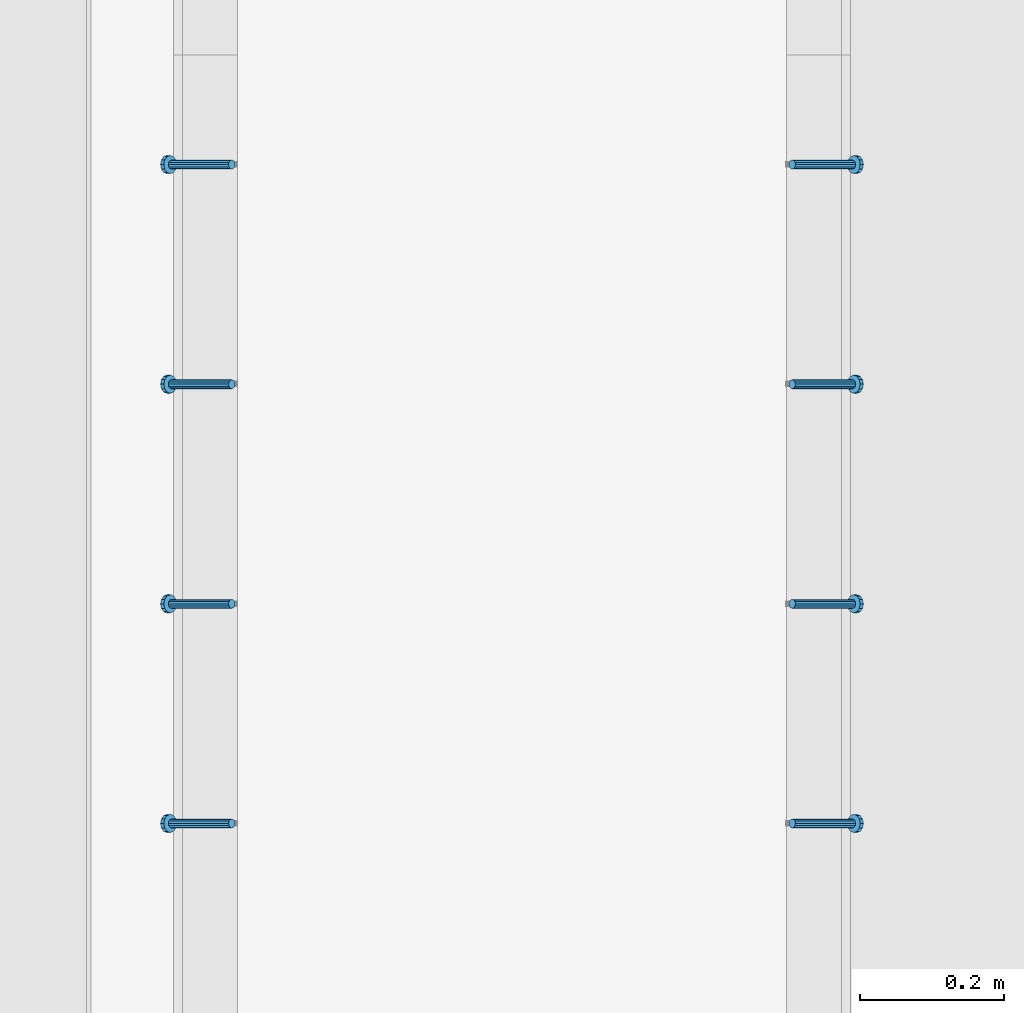
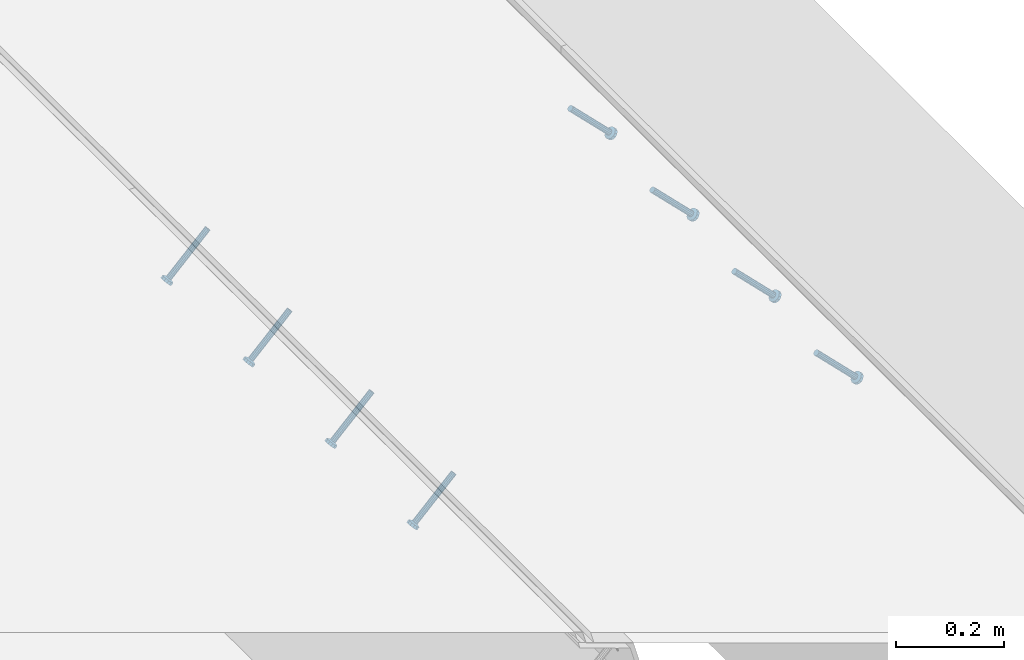
# One storey, part 2186 of 3843: 8 members, 2 elements without a shape of their own.
"""IFC2X3 building model written with IfcOpenShell, lengths in millimetres."""

from ifc_helpers import new_model, si_unit, frame, origin_with_axes, place, context, subcontext, project, spatial, faceted_brep, material, type_object, element, aggregate, save


model = new_model("IFC2X3")

# Units and contexts
model_context = context("Model", 3, precision=1e-05, world=origin_with_axes())
body_context = subcontext(model_context, "Body", "Model", "MODEL_VIEW")
ifc_project = project(units=[si_unit("LENGTHUNIT", "METRE", prefix="MILLI"), si_unit("AREAUNIT", "SQUARE_METRE"), si_unit("VOLUMEUNIT", "CUBIC_METRE"), si_unit("MASSUNIT", "GRAM", prefix="KILO"), si_unit("TIMEUNIT", "SECOND"), si_unit("PLANEANGLEUNIT", "RADIAN"), si_unit("SOLIDANGLEUNIT", "STERADIAN"), si_unit("THERMODYNAMICTEMPERATUREUNIT", "DEGREE_CELSIUS"), si_unit("LUMINOUSINTENSITYUNIT", "LUMEN")], contexts=[model_context])

# Site, building, storey
site_placement = place(None, origin_with_axes())
site = spatial("IfcSite", under=ifc_project, at=site_placement, CompositionType="ELEMENT")
building_placement = place(site_placement, origin_with_axes())
building = spatial("IfcBuilding", under=site, at=building_placement, Name="Undefined", CompositionType="ELEMENT")
storey_placement = place(building_placement, origin_with_axes())
storey = spatial("IfcBuildingStorey", under=building, at=storey_placement, Name="Undefined", CompositionType="ELEMENT", Elevation=0.0)

# Assembly, members
assembly_1_placement = place(storey_placement, origin_with_axes())
assembly_1 = element("IfcElementAssembly", 1, at=assembly_1_placement, inside=storey, Name="EMBED_ANGLE", AssemblyPlace="NOTDEFINED", PredefinedType="RIGID_FRAME")
ifc_material = material(Name="STEEL/A108")
member_type = type_object("IfcMemberType", PredefinedType="NOTDEFINED")
member_1_placement = place(assembly_1_placement, frame((44851.3834999999, 39779.575189209, 30456.1875), z_axis=(0.0, 1.0, 0.0), x_axis=(0.707106781186548, 0.0, -0.707106781186548)))
member_1 = element("IfcMember", 2, at=member_1_placement, type_object=member_type, material=ifc_material, Name="HEADED STUD ANCHOR", context=body_context, shape_type="Brep", body=[
    faceted_brep([(7.27595761418343e-12, -3.18000006675175, 5.5), (0.0, -5.49999999998363, 3.1800000667572), (118.110000000976, -5.49999999999091, 3.1800000667572), (118.110000000983, -3.18000006675175, 5.5), (0.0, -6.3499999046162, 0.0), (118.110000000968, -6.34999990461256, 0.0), (0.0, -5.49999999998363, -3.1800000667572), (118.110000000976, -5.49999999999091, -3.1800000667572), (7.27595761418343e-12, -3.18000006675175, -5.5), (118.110000000983, -3.18000006675175, -5.5), (7.27595761418343e-12, -1.81898940354586e-12, -6.34999990463257), (118.110000000968, -1.81898940354586e-12, -6.34999990463257), (0.0, 3.18000006675175, -5.5), (118.110000000968, 3.18000006674811, -5.5), (7.27595761418343e-12, 5.49999999998363, -3.1800000667572), (118.110000000983, 5.49999999998363, -3.1800000667572), (7.27595761418343e-12, 6.3499999046162, 0.0), (118.110000000976, 6.34999990461256, 0.0), (7.27595761418343e-12, 5.49999999998363, 3.1800000667572), (118.110000000983, 5.49999999998363, 3.1800000667572), (0.0, 3.18000006675175, 5.5), (118.110000000968, 3.18000006674811, 5.5), (7.27595761418343e-12, -1.81898940354586e-12, 6.34999990463257), (118.110000000968, -1.81898940354586e-12, 6.34999990463257), (120.650000000991, -10.9899997710909, 6.34999990463257), (120.650000000998, -6.34000015257152, 10.9899997711182), (120.650000000991, -12.6999998092379, 0.0), (120.650000000991, -10.9899997710909, -6.34999990463257), (120.650000000998, -6.34000015257152, -10.9899997711182), (120.650000000991, -1.81898940354586e-12, -12.6899995803833), (120.650000000991, 6.34000015257152, -10.9899997711182), (120.650000000998, 10.9899997710909, -6.34999990463257), (120.650000000991, 12.6999998092342, 0.0), (120.650000000998, 10.9899997710909, 6.34999990463257), (120.650000000991, 6.34000015257152, 10.9899997711182), (120.650000000991, -1.81898940354586e-12, 12.6899995803833), (127.000000001048, -10.9899997710945, 6.34999990463257), (127.000000001048, -6.34000015257152, 10.9899997711182), (127.000000001048, -12.6999998092342, 0.0), (127.000000001048, -10.9899997710945, -6.34999990463257), (127.000000001048, -6.34000015257152, -10.9899997711182), (127.000000001048, 1.81898940354586e-12, -12.6899995803833), (127.000000001048, 6.34000015256788, -10.9899997711182), (127.000000001048, 10.9899997710909, -6.34999990463257), (127.000000001048, 12.6999998092379, 0.0), (127.000000001048, 10.9899997710909, 6.34999990463257), (127.000000001048, 6.34000015256788, 10.9899997711182), (127.000000001048, 1.81898940354586e-12, 12.6899995803833)], [[[0, 1, 2, 3]], [[1, 4, 5, 2]], [[4, 6, 7, 5]], [[6, 8, 9, 7]], [[8, 10, 11, 9]], [[10, 12, 13, 11]], [[12, 14, 15, 13]], [[14, 16, 17, 15]], [[16, 18, 19, 17]], [[18, 20, 21, 19]], [[20, 22, 23, 21]], [[22, 0, 3, 23]], [[22, 20, 18, 16, 14, 12, 10, 8, 6, 4, 1, 0]], [[3, 2, 24, 25]], [[2, 5, 26, 24]], [[5, 7, 27, 26]], [[7, 9, 28, 27]], [[9, 11, 29, 28]], [[11, 13, 30, 29]], [[13, 15, 31, 30]], [[15, 17, 32, 31]], [[17, 19, 33, 32]], [[19, 21, 34, 33]], [[21, 23, 35, 34]], [[23, 3, 25, 35]], [[25, 24, 36, 37]], [[24, 26, 38, 36]], [[26, 27, 39, 38]], [[27, 28, 40, 39]], [[28, 29, 41, 40]], [[29, 30, 42, 41]], [[30, 31, 43, 42]], [[31, 32, 44, 43]], [[32, 33, 45, 44]], [[33, 34, 46, 45]], [[34, 35, 47, 46]], [[35, 25, 37, 47]], [[38, 39, 40, 41, 42, 43, 44, 45, 46, 47, 37, 36]]]),
])
member_2_placement = place(assembly_1_placement, frame((44851.3834999999, 40084.375189209, 30456.1875), z_axis=(0.0, 1.0, 0.0), x_axis=(0.707106781186548, 0.0, -0.707106781186548)))
member_2 = element("IfcMember", 3, at=member_2_placement, type_object=member_type, material=ifc_material, Name="HEADED STUD ANCHOR", context=body_context, shape_type="Brep", body=[
    faceted_brep([(7.27595761418343e-12, -3.18000006675175, 5.5), (0.0, -5.49999999998363, 3.1800000667572), (118.110000000976, -5.49999999999091, 3.1800000667572), (118.110000000983, -3.18000006675175, 5.5), (0.0, -6.3499999046162, 0.0), (118.110000000968, -6.34999990461256, 0.0), (0.0, -5.49999999998363, -3.1800000667572), (118.110000000976, -5.49999999999091, -3.1800000667572), (7.27595761418343e-12, -3.18000006675175, -5.5), (118.110000000983, -3.18000006675175, -5.5), (7.27595761418343e-12, -1.81898940354586e-12, -6.34999990463257), (118.110000000968, -1.81898940354586e-12, -6.34999990463257), (0.0, 3.18000006675175, -5.5), (118.110000000968, 3.18000006674811, -5.5), (7.27595761418343e-12, 5.49999999998363, -3.1800000667572), (118.110000000983, 5.49999999998363, -3.1800000667572), (7.27595761418343e-12, 6.3499999046162, 0.0), (118.110000000976, 6.34999990461256, 0.0), (7.27595761418343e-12, 5.49999999998363, 3.1800000667572), (118.110000000983, 5.49999999998363, 3.1800000667572), (0.0, 3.18000006675175, 5.5), (118.110000000968, 3.18000006674811, 5.5), (7.27595761418343e-12, -1.81898940354586e-12, 6.34999990463257), (118.110000000968, -1.81898940354586e-12, 6.34999990463257), (120.650000000991, -10.9899997710909, 6.34999990463257), (120.650000000998, -6.34000015257152, 10.9899997711182), (120.650000000991, -12.6999998092379, 0.0), (120.650000000991, -10.9899997710909, -6.34999990463257), (120.650000000998, -6.34000015257152, -10.9899997711182), (120.650000000991, -1.81898940354586e-12, -12.6899995803833), (120.650000000991, 6.34000015257152, -10.9899997711182), (120.650000000998, 10.9899997710909, -6.34999990463257), (120.650000000991, 12.6999998092342, 0.0), (120.650000000998, 10.9899997710909, 6.34999990463257), (120.650000000991, 6.34000015257152, 10.9899997711182), (120.650000000991, -1.81898940354586e-12, 12.6899995803833), (127.000000001048, -10.9899997710945, 6.34999990463257), (127.000000001048, -6.34000015257152, 10.9899997711182), (127.000000001048, -12.6999998092342, 0.0), (127.000000001048, -10.9899997710945, -6.34999990463257), (127.000000001048, -6.34000015257152, -10.9899997711182), (127.000000001048, 1.81898940354586e-12, -12.6899995803833), (127.000000001048, 6.34000015256788, -10.9899997711182), (127.000000001048, 10.9899997710909, -6.34999990463257), (127.000000001048, 12.6999998092379, 0.0), (127.000000001048, 10.9899997710909, 6.34999990463257), (127.000000001048, 6.34000015256788, 10.9899997711182), (127.000000001048, 1.81898940354586e-12, 12.6899995803833)], [[[0, 1, 2, 3]], [[1, 4, 5, 2]], [[4, 6, 7, 5]], [[6, 8, 9, 7]], [[8, 10, 11, 9]], [[10, 12, 13, 11]], [[12, 14, 15, 13]], [[14, 16, 17, 15]], [[16, 18, 19, 17]], [[18, 20, 21, 19]], [[20, 22, 23, 21]], [[22, 0, 3, 23]], [[22, 20, 18, 16, 14, 12, 10, 8, 6, 4, 1, 0]], [[3, 2, 24, 25]], [[2, 5, 26, 24]], [[5, 7, 27, 26]], [[7, 9, 28, 27]], [[9, 11, 29, 28]], [[11, 13, 30, 29]], [[13, 15, 31, 30]], [[15, 17, 32, 31]], [[17, 19, 33, 32]], [[19, 21, 34, 33]], [[21, 23, 35, 34]], [[23, 3, 25, 35]], [[25, 24, 36, 37]], [[24, 26, 38, 36]], [[26, 27, 39, 38]], [[27, 28, 40, 39]], [[28, 29, 41, 40]], [[29, 30, 42, 41]], [[30, 31, 43, 42]], [[31, 32, 44, 43]], [[32, 33, 45, 44]], [[33, 34, 46, 45]], [[34, 35, 47, 46]], [[35, 25, 37, 47]], [[38, 39, 40, 41, 42, 43, 44, 45, 46, 47, 37, 36]]]),
])
member_3_placement = place(assembly_1_placement, frame((44851.3834999999, 40389.175189209, 30456.1875), z_axis=(0.0, 1.0, 0.0), x_axis=(0.707106781186548, 0.0, -0.707106781186548)))
member_3 = element("IfcMember", 4, at=member_3_placement, type_object=member_type, material=ifc_material, Name="HEADED STUD ANCHOR", context=body_context, shape_type="Brep", body=[
    faceted_brep([(7.27595761418343e-12, -3.18000006675175, 5.5), (0.0, -5.49999999998363, 3.1800000667572), (118.110000000976, -5.49999999999091, 3.1800000667572), (118.110000000983, -3.18000006675175, 5.5), (0.0, -6.3499999046162, 0.0), (118.110000000968, -6.34999990461256, 0.0), (0.0, -5.49999999998363, -3.1800000667572), (118.110000000976, -5.49999999999091, -3.1800000667572), (7.27595761418343e-12, -3.18000006675175, -5.5), (118.110000000983, -3.18000006675175, -5.5), (7.27595761418343e-12, -1.81898940354586e-12, -6.34999990463257), (118.110000000968, -1.81898940354586e-12, -6.34999990463257), (0.0, 3.18000006675175, -5.5), (118.110000000968, 3.18000006674811, -5.5), (7.27595761418343e-12, 5.49999999998363, -3.1800000667572), (118.110000000983, 5.49999999998363, -3.1800000667572), (7.27595761418343e-12, 6.3499999046162, 0.0), (118.110000000976, 6.34999990461256, 0.0), (7.27595761418343e-12, 5.49999999998363, 3.1800000667572), (118.110000000983, 5.49999999998363, 3.1800000667572), (0.0, 3.18000006675175, 5.5), (118.110000000968, 3.18000006674811, 5.5), (7.27595761418343e-12, -1.81898940354586e-12, 6.34999990463257), (118.110000000968, -1.81898940354586e-12, 6.34999990463257), (120.650000000991, -10.9899997710909, 6.34999990463257), (120.650000000998, -6.34000015257152, 10.9899997711182), (120.650000000991, -12.6999998092379, 0.0), (120.650000000991, -10.9899997710909, -6.34999990463257), (120.650000000998, -6.34000015257152, -10.9899997711182), (120.650000000991, -1.81898940354586e-12, -12.6899995803833), (120.650000000991, 6.34000015257152, -10.9899997711182), (120.650000000998, 10.9899997710909, -6.34999990463257), (120.650000000991, 12.6999998092342, 0.0), (120.650000000998, 10.9899997710909, 6.34999990463257), (120.650000000991, 6.34000015257152, 10.9899997711182), (120.650000000991, -1.81898940354586e-12, 12.6899995803833), (127.000000001048, -10.9899997710945, 6.34999990463257), (127.000000001048, -6.34000015257152, 10.9899997711182), (127.000000001048, -12.6999998092342, 0.0), (127.000000001048, -10.9899997710945, -6.34999990463257), (127.000000001048, -6.34000015257152, -10.9899997711182), (127.000000001048, 1.81898940354586e-12, -12.6899995803833), (127.000000001048, 6.34000015256788, -10.9899997711182), (127.000000001048, 10.9899997710909, -6.34999990463257), (127.000000001048, 12.6999998092379, 0.0), (127.000000001048, 10.9899997710909, 6.34999990463257), (127.000000001048, 6.34000015256788, 10.9899997711182), (127.000000001048, 1.81898940354586e-12, 12.6899995803833)], [[[0, 1, 2, 3]], [[1, 4, 5, 2]], [[4, 6, 7, 5]], [[6, 8, 9, 7]], [[8, 10, 11, 9]], [[10, 12, 13, 11]], [[12, 14, 15, 13]], [[14, 16, 17, 15]], [[16, 18, 19, 17]], [[18, 20, 21, 19]], [[20, 22, 23, 21]], [[22, 0, 3, 23]], [[22, 20, 18, 16, 14, 12, 10, 8, 6, 4, 1, 0]], [[3, 2, 24, 25]], [[2, 5, 26, 24]], [[5, 7, 27, 26]], [[7, 9, 28, 27]], [[9, 11, 29, 28]], [[11, 13, 30, 29]], [[13, 15, 31, 30]], [[15, 17, 32, 31]], [[17, 19, 33, 32]], [[19, 21, 34, 33]], [[21, 23, 35, 34]], [[23, 3, 25, 35]], [[25, 24, 36, 37]], [[24, 26, 38, 36]], [[26, 27, 39, 38]], [[27, 28, 40, 39]], [[28, 29, 41, 40]], [[29, 30, 42, 41]], [[30, 31, 43, 42]], [[31, 32, 44, 43]], [[32, 33, 45, 44]], [[33, 34, 46, 45]], [[34, 35, 47, 46]], [[35, 25, 37, 47]], [[38, 39, 40, 41, 42, 43, 44, 45, 46, 47, 37, 36]]]),
])
member_4_placement = place(assembly_1_placement, frame((44851.3834999999, 40693.975189209, 30456.1875), z_axis=(0.0, 1.0, 0.0), x_axis=(0.707106781186548, 0.0, -0.707106781186548)))
member_4 = element("IfcMember", 5, at=member_4_placement, type_object=member_type, material=ifc_material, Name="HEADED STUD ANCHOR", context=body_context, shape_type="Brep", body=[
    faceted_brep([(7.27595761418343e-12, -3.18000006675175, 5.5), (0.0, -5.49999999998363, 3.1800000667572), (118.110000000976, -5.49999999999091, 3.1800000667572), (118.110000000983, -3.18000006675175, 5.5), (0.0, -6.3499999046162, 0.0), (118.110000000968, -6.34999990461256, 0.0), (0.0, -5.49999999998363, -3.1800000667572), (118.110000000976, -5.49999999999091, -3.1800000667572), (7.27595761418343e-12, -3.18000006675175, -5.5), (118.110000000983, -3.18000006675175, -5.5), (7.27595761418343e-12, -1.81898940354586e-12, -6.34999990463257), (118.110000000968, -1.81898940354586e-12, -6.34999990463257), (0.0, 3.18000006675175, -5.5), (118.110000000968, 3.18000006674811, -5.5), (7.27595761418343e-12, 5.49999999998363, -3.1800000667572), (118.110000000983, 5.49999999998363, -3.1800000667572), (7.27595761418343e-12, 6.3499999046162, 0.0), (118.110000000976, 6.34999990461256, 0.0), (7.27595761418343e-12, 5.49999999998363, 3.1800000667572), (118.110000000983, 5.49999999998363, 3.1800000667572), (0.0, 3.18000006675175, 5.5), (118.110000000968, 3.18000006674811, 5.5), (7.27595761418343e-12, -1.81898940354586e-12, 6.34999990463257), (118.110000000968, -1.81898940354586e-12, 6.34999990463257), (120.650000000991, -10.9899997710909, 6.34999990463257), (120.650000000998, -6.34000015257152, 10.9899997711182), (120.650000000991, -12.6999998092379, 0.0), (120.650000000991, -10.9899997710909, -6.34999990463257), (120.650000000998, -6.34000015257152, -10.9899997711182), (120.650000000991, -1.81898940354586e-12, -12.6899995803833), (120.650000000991, 6.34000015257152, -10.9899997711182), (120.650000000998, 10.9899997710909, -6.34999990463257), (120.650000000991, 12.6999998092342, 0.0), (120.650000000998, 10.9899997710909, 6.34999990463257), (120.650000000991, 6.34000015257152, 10.9899997711182), (120.650000000991, -1.81898940354586e-12, 12.6899995803833), (127.000000001048, -10.9899997710945, 6.34999990463257), (127.000000001048, -6.34000015257152, 10.9899997711182), (127.000000001048, -12.6999998092342, 0.0), (127.000000001048, -10.9899997710945, -6.34999990463257), (127.000000001048, -6.34000015257152, -10.9899997711182), (127.000000001048, 1.81898940354586e-12, -12.6899995803833), (127.000000001048, 6.34000015256788, -10.9899997711182), (127.000000001048, 10.9899997710909, -6.34999990463257), (127.000000001048, 12.6999998092379, 0.0), (127.000000001048, 10.9899997710909, 6.34999990463257), (127.000000001048, 6.34000015256788, 10.9899997711182), (127.000000001048, 1.81898940354586e-12, 12.6899995803833)], [[[0, 1, 2, 3]], [[1, 4, 5, 2]], [[4, 6, 7, 5]], [[6, 8, 9, 7]], [[8, 10, 11, 9]], [[10, 12, 13, 11]], [[12, 14, 15, 13]], [[14, 16, 17, 15]], [[16, 18, 19, 17]], [[18, 20, 21, 19]], [[20, 22, 23, 21]], [[22, 0, 3, 23]], [[22, 20, 18, 16, 14, 12, 10, 8, 6, 4, 1, 0]], [[3, 2, 24, 25]], [[2, 5, 26, 24]], [[5, 7, 27, 26]], [[7, 9, 28, 27]], [[9, 11, 29, 28]], [[11, 13, 30, 29]], [[13, 15, 31, 30]], [[15, 17, 32, 31]], [[17, 19, 33, 32]], [[19, 21, 34, 33]], [[21, 23, 35, 34]], [[23, 3, 25, 35]], [[25, 24, 36, 37]], [[24, 26, 38, 36]], [[26, 27, 39, 38]], [[27, 28, 40, 39]], [[28, 29, 41, 40]], [[29, 30, 42, 41]], [[30, 31, 43, 42]], [[31, 32, 44, 43]], [[32, 33, 45, 44]], [[33, 34, 46, 45]], [[34, 35, 47, 46]], [[35, 25, 37, 47]], [[38, 39, 40, 41, 42, 43, 44, 45, 46, 47, 37, 36]]]),
])
aggregate(assembly_1, [member_1, member_2, member_3, member_4])

assembly_2_placement = place(storey_placement, origin_with_axes())
assembly_2 = element("IfcElementAssembly", 6, at=assembly_2_placement, inside=storey, Name="EMBED_ANGLE", AssemblyPlace="NOTDEFINED", PredefinedType="RIGID_FRAME")
member_5_placement = place(assembly_2_placement, frame((44073.5085000003, 39779.575189209, 30456.1874999998), z_axis=(0.0, -1.0, 0.0), x_axis=(-0.707106781186548, 0.0, -0.707106781186548)))
member_5 = element("IfcMember", 7, at=member_5_placement, type_object=member_type, material=ifc_material, Name="HEADED STUD ANCHOR", context=body_context, shape_type="Brep", body=[
    faceted_brep([(7.27595761418343e-12, -3.18000006675175, 5.5), (0.0, -5.49999999998363, 3.1800000667572), (118.110000000976, -5.49999999999091, 3.1800000667572), (118.110000000983, -3.18000006675175, 5.5), (0.0, -6.3499999046162, 0.0), (118.110000000968, -6.34999990461256, 0.0), (0.0, -5.49999999998363, -3.1800000667572), (118.110000000976, -5.49999999999091, -3.1800000667572), (7.27595761418343e-12, -3.18000006675175, -5.5), (118.110000000983, -3.18000006675175, -5.5), (7.27595761418343e-12, -1.81898940354586e-12, -6.34999990463257), (118.110000000968, -1.81898940354586e-12, -6.34999990463257), (0.0, 3.18000006675175, -5.5), (118.110000000968, 3.18000006674811, -5.5), (7.27595761418343e-12, 5.49999999998363, -3.1800000667572), (118.110000000983, 5.49999999998363, -3.1800000667572), (7.27595761418343e-12, 6.3499999046162, 0.0), (118.110000000976, 6.34999990461256, 0.0), (7.27595761418343e-12, 5.49999999998363, 3.1800000667572), (118.110000000983, 5.49999999998363, 3.1800000667572), (0.0, 3.18000006675175, 5.5), (118.110000000968, 3.18000006674811, 5.5), (7.27595761418343e-12, -1.81898940354586e-12, 6.34999990463257), (118.110000000968, -1.81898940354586e-12, 6.34999990463257), (120.650000000991, -10.9899997710909, 6.34999990463257), (120.650000000998, -6.34000015257152, 10.9899997711182), (120.650000000991, -12.6999998092379, 0.0), (120.650000000991, -10.9899997710909, -6.34999990463257), (120.650000000998, -6.34000015257152, -10.9899997711182), (120.650000000991, -1.81898940354586e-12, -12.6899995803833), (120.650000000991, 6.34000015257152, -10.9899997711182), (120.650000000998, 10.9899997710909, -6.34999990463257), (120.650000000991, 12.6999998092342, 0.0), (120.650000000998, 10.9899997710909, 6.34999990463257), (120.650000000991, 6.34000015257152, 10.9899997711182), (120.650000000991, -1.81898940354586e-12, 12.6899995803833), (127.000000001048, -10.9899997710945, 6.34999990463257), (127.000000001048, -6.34000015257152, 10.9899997711182), (127.000000001048, -12.6999998092342, 0.0), (127.000000001048, -10.9899997710945, -6.34999990463257), (127.000000001048, -6.34000015257152, -10.9899997711182), (127.000000001048, 1.81898940354586e-12, -12.6899995803833), (127.000000001048, 6.34000015256788, -10.9899997711182), (127.000000001048, 10.9899997710909, -6.34999990463257), (127.000000001048, 12.6999998092379, 0.0), (127.000000001048, 10.9899997710909, 6.34999990463257), (127.000000001048, 6.34000015256788, 10.9899997711182), (127.000000001048, 1.81898940354586e-12, 12.6899995803833)], [[[0, 1, 2, 3]], [[1, 4, 5, 2]], [[4, 6, 7, 5]], [[6, 8, 9, 7]], [[8, 10, 11, 9]], [[10, 12, 13, 11]], [[12, 14, 15, 13]], [[14, 16, 17, 15]], [[16, 18, 19, 17]], [[18, 20, 21, 19]], [[20, 22, 23, 21]], [[22, 0, 3, 23]], [[22, 20, 18, 16, 14, 12, 10, 8, 6, 4, 1, 0]], [[3, 2, 24, 25]], [[2, 5, 26, 24]], [[5, 7, 27, 26]], [[7, 9, 28, 27]], [[9, 11, 29, 28]], [[11, 13, 30, 29]], [[13, 15, 31, 30]], [[15, 17, 32, 31]], [[17, 19, 33, 32]], [[19, 21, 34, 33]], [[21, 23, 35, 34]], [[23, 3, 25, 35]], [[25, 24, 36, 37]], [[24, 26, 38, 36]], [[26, 27, 39, 38]], [[27, 28, 40, 39]], [[28, 29, 41, 40]], [[29, 30, 42, 41]], [[30, 31, 43, 42]], [[31, 32, 44, 43]], [[32, 33, 45, 44]], [[33, 34, 46, 45]], [[34, 35, 47, 46]], [[35, 25, 37, 47]], [[38, 39, 40, 41, 42, 43, 44, 45, 46, 47, 37, 36]]]),
])
member_6_placement = place(assembly_2_placement, frame((44073.5085000003, 40084.375189209, 30456.1874999998), z_axis=(0.0, -1.0, 0.0), x_axis=(-0.707106781186548, 0.0, -0.707106781186548)))
member_6 = element("IfcMember", 8, at=member_6_placement, type_object=member_type, material=ifc_material, Name="HEADED STUD ANCHOR", context=body_context, shape_type="Brep", body=[
    faceted_brep([(7.27595761418343e-12, -3.18000006675175, 5.5), (0.0, -5.49999999998363, 3.1800000667572), (118.110000000976, -5.49999999999091, 3.1800000667572), (118.110000000983, -3.18000006675175, 5.5), (0.0, -6.3499999046162, 0.0), (118.110000000968, -6.34999990461256, 0.0), (0.0, -5.49999999998363, -3.1800000667572), (118.110000000976, -5.49999999999091, -3.1800000667572), (7.27595761418343e-12, -3.18000006675175, -5.5), (118.110000000983, -3.18000006675175, -5.5), (7.27595761418343e-12, -1.81898940354586e-12, -6.34999990463257), (118.110000000968, -1.81898940354586e-12, -6.34999990463257), (0.0, 3.18000006675175, -5.5), (118.110000000968, 3.18000006674811, -5.5), (7.27595761418343e-12, 5.49999999998363, -3.1800000667572), (118.110000000983, 5.49999999998363, -3.1800000667572), (7.27595761418343e-12, 6.3499999046162, 0.0), (118.110000000976, 6.34999990461256, 0.0), (7.27595761418343e-12, 5.49999999998363, 3.1800000667572), (118.110000000983, 5.49999999998363, 3.1800000667572), (0.0, 3.18000006675175, 5.5), (118.110000000968, 3.18000006674811, 5.5), (7.27595761418343e-12, -1.81898940354586e-12, 6.34999990463257), (118.110000000968, -1.81898940354586e-12, 6.34999990463257), (120.650000000991, -10.9899997710909, 6.34999990463257), (120.650000000998, -6.34000015257152, 10.9899997711182), (120.650000000991, -12.6999998092379, 0.0), (120.650000000991, -10.9899997710909, -6.34999990463257), (120.650000000998, -6.34000015257152, -10.9899997711182), (120.650000000991, -1.81898940354586e-12, -12.6899995803833), (120.650000000991, 6.34000015257152, -10.9899997711182), (120.650000000998, 10.9899997710909, -6.34999990463257), (120.650000000991, 12.6999998092342, 0.0), (120.650000000998, 10.9899997710909, 6.34999990463257), (120.650000000991, 6.34000015257152, 10.9899997711182), (120.650000000991, -1.81898940354586e-12, 12.6899995803833), (127.000000001048, -10.9899997710945, 6.34999990463257), (127.000000001048, -6.34000015257152, 10.9899997711182), (127.000000001048, -12.6999998092342, 0.0), (127.000000001048, -10.9899997710945, -6.34999990463257), (127.000000001048, -6.34000015257152, -10.9899997711182), (127.000000001048, 1.81898940354586e-12, -12.6899995803833), (127.000000001048, 6.34000015256788, -10.9899997711182), (127.000000001048, 10.9899997710909, -6.34999990463257), (127.000000001048, 12.6999998092379, 0.0), (127.000000001048, 10.9899997710909, 6.34999990463257), (127.000000001048, 6.34000015256788, 10.9899997711182), (127.000000001048, 1.81898940354586e-12, 12.6899995803833)], [[[0, 1, 2, 3]], [[1, 4, 5, 2]], [[4, 6, 7, 5]], [[6, 8, 9, 7]], [[8, 10, 11, 9]], [[10, 12, 13, 11]], [[12, 14, 15, 13]], [[14, 16, 17, 15]], [[16, 18, 19, 17]], [[18, 20, 21, 19]], [[20, 22, 23, 21]], [[22, 0, 3, 23]], [[22, 20, 18, 16, 14, 12, 10, 8, 6, 4, 1, 0]], [[3, 2, 24, 25]], [[2, 5, 26, 24]], [[5, 7, 27, 26]], [[7, 9, 28, 27]], [[9, 11, 29, 28]], [[11, 13, 30, 29]], [[13, 15, 31, 30]], [[15, 17, 32, 31]], [[17, 19, 33, 32]], [[19, 21, 34, 33]], [[21, 23, 35, 34]], [[23, 3, 25, 35]], [[25, 24, 36, 37]], [[24, 26, 38, 36]], [[26, 27, 39, 38]], [[27, 28, 40, 39]], [[28, 29, 41, 40]], [[29, 30, 42, 41]], [[30, 31, 43, 42]], [[31, 32, 44, 43]], [[32, 33, 45, 44]], [[33, 34, 46, 45]], [[34, 35, 47, 46]], [[35, 25, 37, 47]], [[38, 39, 40, 41, 42, 43, 44, 45, 46, 47, 37, 36]]]),
])
member_7_placement = place(assembly_2_placement, frame((44073.5085000003, 40389.175189209, 30456.1874999998), z_axis=(0.0, -1.0, 0.0), x_axis=(-0.707106781186548, 0.0, -0.707106781186548)))
member_7 = element("IfcMember", 9, at=member_7_placement, type_object=member_type, material=ifc_material, Name="HEADED STUD ANCHOR", context=body_context, shape_type="Brep", body=[
    faceted_brep([(7.27595761418343e-12, -3.18000006675175, 5.5), (0.0, -5.49999999998363, 3.1800000667572), (118.110000000976, -5.49999999999091, 3.1800000667572), (118.110000000983, -3.18000006675175, 5.5), (0.0, -6.3499999046162, 0.0), (118.110000000968, -6.34999990461256, 0.0), (0.0, -5.49999999998363, -3.1800000667572), (118.110000000976, -5.49999999999091, -3.1800000667572), (7.27595761418343e-12, -3.18000006675175, -5.5), (118.110000000983, -3.18000006675175, -5.5), (7.27595761418343e-12, -1.81898940354586e-12, -6.34999990463257), (118.110000000968, -1.81898940354586e-12, -6.34999990463257), (0.0, 3.18000006675175, -5.5), (118.110000000968, 3.18000006674811, -5.5), (7.27595761418343e-12, 5.49999999998363, -3.1800000667572), (118.110000000983, 5.49999999998363, -3.1800000667572), (7.27595761418343e-12, 6.3499999046162, 0.0), (118.110000000976, 6.34999990461256, 0.0), (7.27595761418343e-12, 5.49999999998363, 3.1800000667572), (118.110000000983, 5.49999999998363, 3.1800000667572), (0.0, 3.18000006675175, 5.5), (118.110000000968, 3.18000006674811, 5.5), (7.27595761418343e-12, -1.81898940354586e-12, 6.34999990463257), (118.110000000968, -1.81898940354586e-12, 6.34999990463257), (120.650000000991, -10.9899997710909, 6.34999990463257), (120.650000000998, -6.34000015257152, 10.9899997711182), (120.650000000991, -12.6999998092379, 0.0), (120.650000000991, -10.9899997710909, -6.34999990463257), (120.650000000998, -6.34000015257152, -10.9899997711182), (120.650000000991, -1.81898940354586e-12, -12.6899995803833), (120.650000000991, 6.34000015257152, -10.9899997711182), (120.650000000998, 10.9899997710909, -6.34999990463257), (120.650000000991, 12.6999998092342, 0.0), (120.650000000998, 10.9899997710909, 6.34999990463257), (120.650000000991, 6.34000015257152, 10.9899997711182), (120.650000000991, -1.81898940354586e-12, 12.6899995803833), (127.000000001048, -10.9899997710945, 6.34999990463257), (127.000000001048, -6.34000015257152, 10.9899997711182), (127.000000001048, -12.6999998092342, 0.0), (127.000000001048, -10.9899997710945, -6.34999990463257), (127.000000001048, -6.34000015257152, -10.9899997711182), (127.000000001048, 1.81898940354586e-12, -12.6899995803833), (127.000000001048, 6.34000015256788, -10.9899997711182), (127.000000001048, 10.9899997710909, -6.34999990463257), (127.000000001048, 12.6999998092379, 0.0), (127.000000001048, 10.9899997710909, 6.34999990463257), (127.000000001048, 6.34000015256788, 10.9899997711182), (127.000000001048, 1.81898940354586e-12, 12.6899995803833)], [[[0, 1, 2, 3]], [[1, 4, 5, 2]], [[4, 6, 7, 5]], [[6, 8, 9, 7]], [[8, 10, 11, 9]], [[10, 12, 13, 11]], [[12, 14, 15, 13]], [[14, 16, 17, 15]], [[16, 18, 19, 17]], [[18, 20, 21, 19]], [[20, 22, 23, 21]], [[22, 0, 3, 23]], [[22, 20, 18, 16, 14, 12, 10, 8, 6, 4, 1, 0]], [[3, 2, 24, 25]], [[2, 5, 26, 24]], [[5, 7, 27, 26]], [[7, 9, 28, 27]], [[9, 11, 29, 28]], [[11, 13, 30, 29]], [[13, 15, 31, 30]], [[15, 17, 32, 31]], [[17, 19, 33, 32]], [[19, 21, 34, 33]], [[21, 23, 35, 34]], [[23, 3, 25, 35]], [[25, 24, 36, 37]], [[24, 26, 38, 36]], [[26, 27, 39, 38]], [[27, 28, 40, 39]], [[28, 29, 41, 40]], [[29, 30, 42, 41]], [[30, 31, 43, 42]], [[31, 32, 44, 43]], [[32, 33, 45, 44]], [[33, 34, 46, 45]], [[34, 35, 47, 46]], [[35, 25, 37, 47]], [[38, 39, 40, 41, 42, 43, 44, 45, 46, 47, 37, 36]]]),
])
member_8_placement = place(assembly_2_placement, frame((44073.5085000003, 40693.975189209, 30456.1874999998), z_axis=(0.0, -1.0, 0.0), x_axis=(-0.707106781186548, 0.0, -0.707106781186548)))
member_8 = element("IfcMember", 10, at=member_8_placement, type_object=member_type, material=ifc_material, Name="HEADED STUD ANCHOR", context=body_context, shape_type="Brep", body=[
    faceted_brep([(7.27595761418343e-12, -3.18000006675175, 5.5), (0.0, -5.49999999998363, 3.1800000667572), (118.110000000976, -5.49999999999091, 3.1800000667572), (118.110000000983, -3.18000006675175, 5.5), (0.0, -6.3499999046162, 0.0), (118.110000000968, -6.34999990461256, 0.0), (0.0, -5.49999999998363, -3.1800000667572), (118.110000000976, -5.49999999999091, -3.1800000667572), (7.27595761418343e-12, -3.18000006675175, -5.5), (118.110000000983, -3.18000006675175, -5.5), (7.27595761418343e-12, -1.81898940354586e-12, -6.34999990463257), (118.110000000968, -1.81898940354586e-12, -6.34999990463257), (0.0, 3.18000006675175, -5.5), (118.110000000968, 3.18000006674811, -5.5), (7.27595761418343e-12, 5.49999999998363, -3.1800000667572), (118.110000000983, 5.49999999998363, -3.1800000667572), (7.27595761418343e-12, 6.3499999046162, 0.0), (118.110000000976, 6.34999990461256, 0.0), (7.27595761418343e-12, 5.49999999998363, 3.1800000667572), (118.110000000983, 5.49999999998363, 3.1800000667572), (0.0, 3.18000006675175, 5.5), (118.110000000968, 3.18000006674811, 5.5), (7.27595761418343e-12, -1.81898940354586e-12, 6.34999990463257), (118.110000000968, -1.81898940354586e-12, 6.34999990463257), (120.650000000991, -10.9899997710909, 6.34999990463257), (120.650000000998, -6.34000015257152, 10.9899997711182), (120.650000000991, -12.6999998092379, 0.0), (120.650000000991, -10.9899997710909, -6.34999990463257), (120.650000000998, -6.34000015257152, -10.9899997711182), (120.650000000991, -1.81898940354586e-12, -12.6899995803833), (120.650000000991, 6.34000015257152, -10.9899997711182), (120.650000000998, 10.9899997710909, -6.34999990463257), (120.650000000991, 12.6999998092342, 0.0), (120.650000000998, 10.9899997710909, 6.34999990463257), (120.650000000991, 6.34000015257152, 10.9899997711182), (120.650000000991, -1.81898940354586e-12, 12.6899995803833), (127.000000001048, -10.9899997710945, 6.34999990463257), (127.000000001048, -6.34000015257152, 10.9899997711182), (127.000000001048, -12.6999998092342, 0.0), (127.000000001048, -10.9899997710945, -6.34999990463257), (127.000000001048, -6.34000015257152, -10.9899997711182), (127.000000001048, 1.81898940354586e-12, -12.6899995803833), (127.000000001048, 6.34000015256788, -10.9899997711182), (127.000000001048, 10.9899997710909, -6.34999990463257), (127.000000001048, 12.6999998092379, 0.0), (127.000000001048, 10.9899997710909, 6.34999990463257), (127.000000001048, 6.34000015256788, 10.9899997711182), (127.000000001048, 1.81898940354586e-12, 12.6899995803833)], [[[0, 1, 2, 3]], [[1, 4, 5, 2]], [[4, 6, 7, 5]], [[6, 8, 9, 7]], [[8, 10, 11, 9]], [[10, 12, 13, 11]], [[12, 14, 15, 13]], [[14, 16, 17, 15]], [[16, 18, 19, 17]], [[18, 20, 21, 19]], [[20, 22, 23, 21]], [[22, 0, 3, 23]], [[22, 20, 18, 16, 14, 12, 10, 8, 6, 4, 1, 0]], [[3, 2, 24, 25]], [[2, 5, 26, 24]], [[5, 7, 27, 26]], [[7, 9, 28, 27]], [[9, 11, 29, 28]], [[11, 13, 30, 29]], [[13, 15, 31, 30]], [[15, 17, 32, 31]], [[17, 19, 33, 32]], [[19, 21, 34, 33]], [[21, 23, 35, 34]], [[23, 3, 25, 35]], [[25, 24, 36, 37]], [[24, 26, 38, 36]], [[26, 27, 39, 38]], [[27, 28, 40, 39]], [[28, 29, 41, 40]], [[29, 30, 42, 41]], [[30, 31, 43, 42]], [[31, 32, 44, 43]], [[32, 33, 45, 44]], [[33, 34, 46, 45]], [[34, 35, 47, 46]], [[35, 25, 37, 47]], [[38, 39, 40, 41, 42, 43, 44, 45, 46, 47, 37, 36]]]),
])
aggregate(assembly_2, [member_5, member_6, member_7, member_8])

save(model, "model.ifc")
